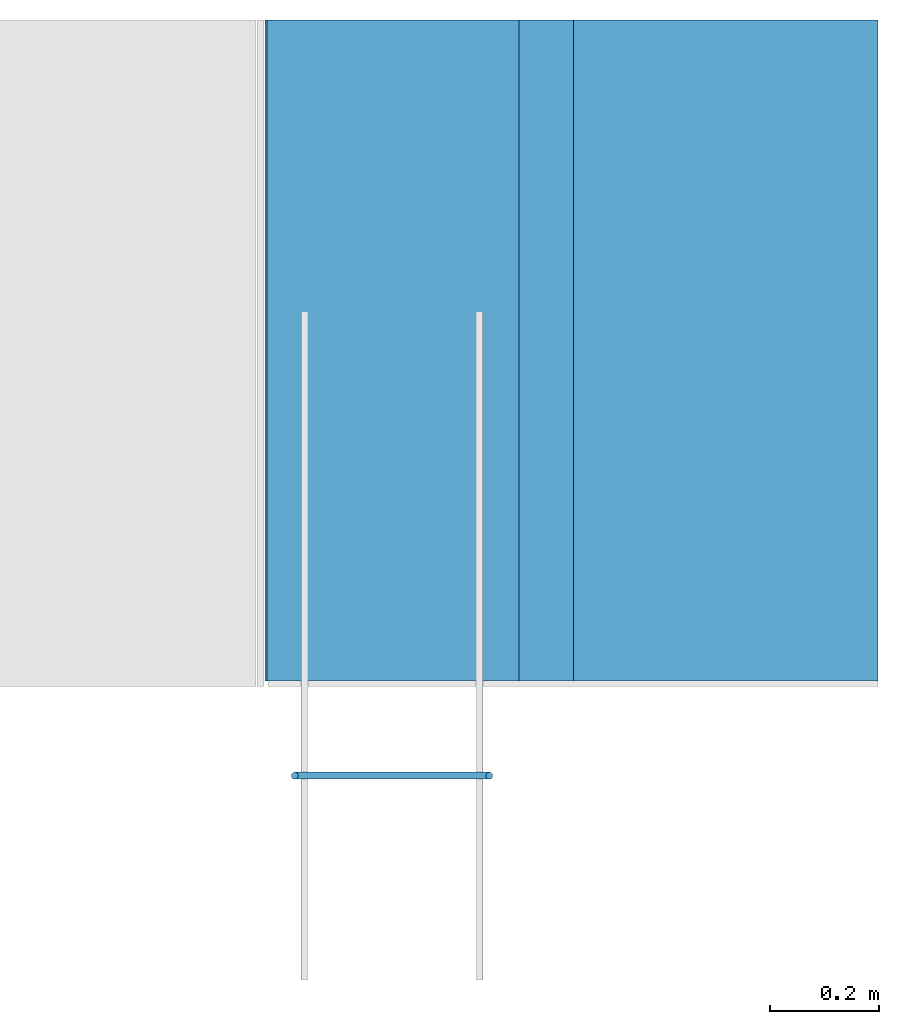
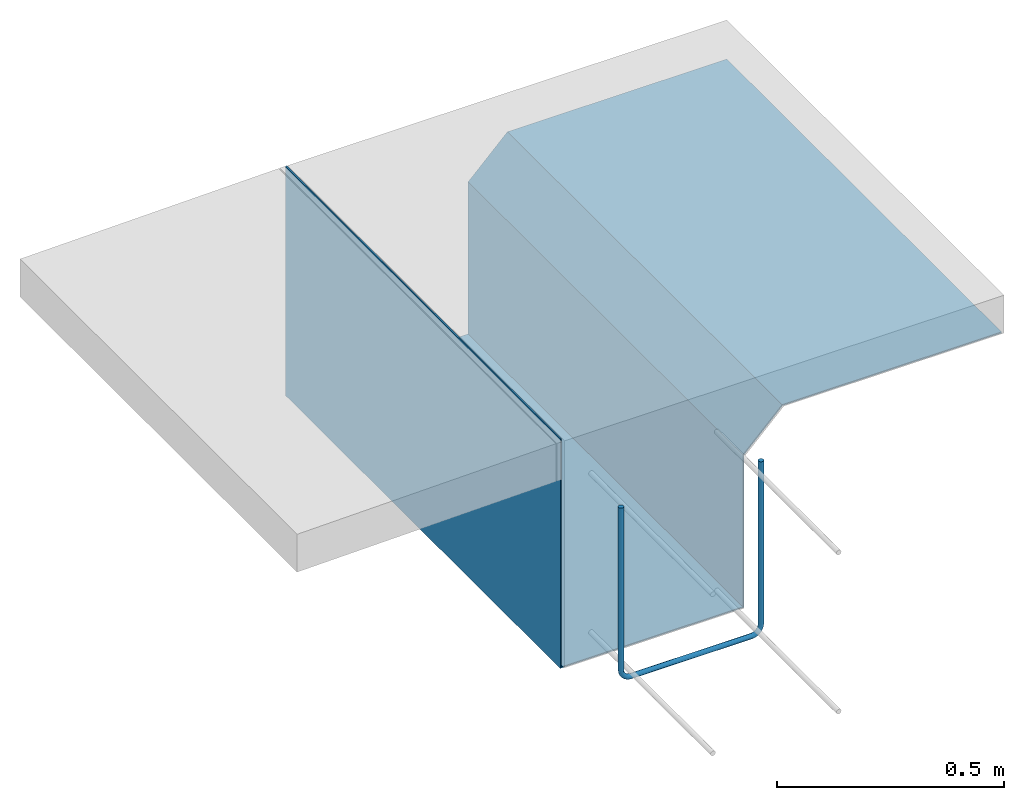
# One storey, part 2 of 2: 2 walls.
"""IFC4 building model written with IfcOpenShell, lengths in feet."""

from ifc_helpers import new_model, entity, si_unit, converted_unit, derived_unit, direction, frame, origin, place, context, subcontext, project, spatial, material, type_object, element, save


model = new_model("IFC4")

# Units and contexts
model_context = context("Model", 3, precision=0.0001, world=origin(), true_north=direction((6.12303176911189e-17, 1.0)))
body_context = subcontext(model_context, "Body", "Model", "MODEL_VIEW")
ifc_project = project(units=[converted_unit("LENGTHUNIT", "FOOT", entity("IfcRatioMeasure", 0.3048), si_unit("LENGTHUNIT", "METRE"), dimensions=[1, 0, 0, 0, 0, 0, 0]), converted_unit("AREAUNIT", "SQUARE FOOT", entity("IfcRatioMeasure", 0.09290304), si_unit("AREAUNIT", "SQUARE_METRE"), dimensions=[2, 0, 0, 0, 0, 0, 0]), converted_unit("VOLUMEUNIT", "CUBIC FOOT", entity("IfcRatioMeasure", 0.028316846592), si_unit("VOLUMEUNIT", "CUBIC_METRE"), dimensions=[3, 0, 0, 0, 0, 0, 0]), converted_unit("PLANEANGLEUNIT", "DEGREE", entity("IfcRatioMeasure", 0.0174532925199433), si_unit("PLANEANGLEUNIT", "RADIAN"), dimensions=[0, 0, 0, 0, 0, 0, 0]), si_unit("MASSUNIT", "GRAM", prefix="KILO"), derived_unit("MASSDENSITYUNIT", [(si_unit("MASSUNIT", "GRAM", prefix="KILO"), 1), (si_unit("LENGTHUNIT", "METRE"), -3)]), derived_unit("MOMENTOFINERTIAUNIT", [(si_unit("LENGTHUNIT", "METRE"), 4)]), si_unit("TIMEUNIT", "SECOND"), si_unit("FREQUENCYUNIT", "HERTZ"), si_unit("THERMODYNAMICTEMPERATUREUNIT", "DEGREE_CELSIUS"), derived_unit("THERMALTRANSMITTANCEUNIT", [(si_unit("MASSUNIT", "GRAM", prefix="KILO"), 1), (si_unit("THERMODYNAMICTEMPERATUREUNIT", "KELVIN"), -1), (si_unit("TIMEUNIT", "SECOND"), -3)]), derived_unit("VOLUMETRICFLOWRATEUNIT", [(si_unit("LENGTHUNIT", "METRE"), 3), (si_unit("TIMEUNIT", "SECOND"), -1)]), si_unit("ELECTRICCURRENTUNIT", "AMPERE"), si_unit("ELECTRICVOLTAGEUNIT", "VOLT"), si_unit("POWERUNIT", "WATT"), si_unit("FORCEUNIT", "NEWTON"), si_unit("ILLUMINANCEUNIT", "LUX"), si_unit("LUMINOUSFLUXUNIT", "LUMEN"), si_unit("LUMINOUSINTENSITYUNIT", "CANDELA"), derived_unit("USERDEFINED", [(si_unit("MASSUNIT", "GRAM", prefix="KILO"), -1), (si_unit("LENGTHUNIT", "METRE"), -2), (si_unit("TIMEUNIT", "SECOND"), 3), (si_unit("LUMINOUSFLUXUNIT", "LUMEN"), 1)]), derived_unit("LINEARVELOCITYUNIT", [(si_unit("LENGTHUNIT", "METRE"), 1), (si_unit("TIMEUNIT", "SECOND"), -1)]), si_unit("PRESSUREUNIT", "PASCAL"), derived_unit("USERDEFINED", [(si_unit("LENGTHUNIT", "METRE"), -2), (si_unit("MASSUNIT", "GRAM", prefix="KILO"), 1), (si_unit("TIMEUNIT", "SECOND"), -2)]), derived_unit("LINEARFORCEUNIT", [(si_unit("MASSUNIT", "GRAM", prefix="KILO"), 1), (si_unit("LENGTHUNIT", "METRE"), 1), (si_unit("TIMEUNIT", "SECOND"), -2), (si_unit("LENGTHUNIT", "METRE"), -1)]), derived_unit("PLANARFORCEUNIT", [(si_unit("MASSUNIT", "GRAM", prefix="KILO"), 1), (si_unit("LENGTHUNIT", "METRE"), 1), (si_unit("TIMEUNIT", "SECOND"), -2), (si_unit("LENGTHUNIT", "METRE"), -2)])], contexts=[model_context])

# Site, building, storey
site_placement = place(None, origin())
site = spatial("IfcSite", under=ifc_project, at=site_placement, CompositionType="ELEMENT")
building_placement = place(site_placement, origin())
building = spatial("IfcBuilding", under=site, at=building_placement, CompositionType="ELEMENT")
storey_placement = place(building_placement, frame((0.0, 0.0, -8.0)))
storey = spatial("IfcBuildingStorey", under=building, at=storey_placement, CompositionType="ELEMENT", Elevation=-8.0)

# Walls
ifc_material_1 = material(Category="Materials")
wall_type_1 = type_object("IfcWallType", Name="Dowel2:Dowel", PredefinedType="NOTDEFINED", material=ifc_material_1)
wall_1_placement = place(storey_placement, frame((1459.41212853002, 1.44531249999566, 6.14583333332428)))
cartesian_point_1 = entity("IfcCartesianPoint", [0.0, 0.020833333333343, 1.54252768189775])
vertex_point_1 = entity("IfcVertexPoint", cartesian_point_1)
cartesian_point_2 = entity("IfcCartesianPoint", [0.0416666666665151, 0.0208333333333424, 1.54252768189775])
vertex_point_2 = entity("IfcVertexPoint", cartesian_point_2)
cartesian_point_3 = entity("IfcCartesianPoint", [0.0208333333332575, 0.0208333333333428, 1.54252768189775])
ifc_direction_1 = entity("IfcDirection", [0.0, 0.0, 1.0])
ifc_direction_2 = entity("IfcDirection", [1.0, 0.0, 0.0])
edge_curve_1 = entity("IfcEdgeCurve", vertex_point_1, vertex_point_2, entity("IfcTrimmedCurve", entity("IfcCircle", entity("IfcAxis2Placement3D", cartesian_point_3, ifc_direction_1, ifc_direction_2), 0.0208333333333333), [cartesian_point_1], [cartesian_point_2], True, "CARTESIAN"), True)
edge_curve_2 = entity("IfcEdgeCurve", vertex_point_2, vertex_point_1, entity("IfcTrimmedCurve", entity("IfcCircle", entity("IfcAxis2Placement3D", cartesian_point_3, ifc_direction_1, ifc_direction_2), 0.0208333333333333), [cartesian_point_2], [cartesian_point_1], True, "CARTESIAN"), True)
ifc_direction_3 = entity("IfcDirection", [0.0, -1.0, 0.0])
cartesian_point_4 = entity("IfcCartesianPoint", [0.0, 0.0208333333333384, 0.104166666666667])
vertex_point_3 = entity("IfcVertexPoint", cartesian_point_4)
ifc_direction_4 = entity("IfcDirection", [0.0, 0.0, -1.0])
edge_curve_3 = entity("IfcEdgeCurve", vertex_point_1, vertex_point_3, entity("IfcTrimmedCurve", entity("IfcLine", cartesian_point_1, entity("IfcVector", ifc_direction_4, 1.0)), [cartesian_point_1], [cartesian_point_4], True, "CARTESIAN"), True)
cartesian_point_5 = entity("IfcCartesianPoint", [0.0416666666665151, 0.020833333333337, 0.104166666666667])
vertex_point_4 = entity("IfcVertexPoint", cartesian_point_5)
cartesian_point_6 = entity("IfcCartesianPoint", [0.0208333333332575, 0.0208333333333381, 0.104166666666667])
edge_curve_4 = entity("IfcEdgeCurve", vertex_point_3, vertex_point_4, entity("IfcTrimmedCurve", entity("IfcCircle", entity("IfcAxis2Placement3D", cartesian_point_6, ifc_direction_1, ifc_direction_2), 0.0208333333333333), [cartesian_point_4], [cartesian_point_5], True, "CARTESIAN"), True)
edge_curve_5 = entity("IfcEdgeCurve", vertex_point_4, vertex_point_2, entity("IfcTrimmedCurve", entity("IfcLine", cartesian_point_2, entity("IfcVector", ifc_direction_1, 1.0)), [cartesian_point_5], [cartesian_point_2], True, "CARTESIAN"), True)
edge_curve_6 = entity("IfcEdgeCurve", vertex_point_4, vertex_point_3, entity("IfcTrimmedCurve", entity("IfcCircle", entity("IfcAxis2Placement3D", cartesian_point_6, ifc_direction_1, ifc_direction_2), 0.0208333333333333), [cartesian_point_5], [cartesian_point_4], True, "CARTESIAN"), True)
cartesian_point_7 = entity("IfcCartesianPoint", [0.104166666666515, 0.0208333333333366, 0.041666666666738])
vertex_point_5 = entity("IfcVertexPoint", cartesian_point_7)
cartesian_point_8 = entity("IfcCartesianPoint", [0.104166666666515, 0.0208333333333373, 0.104166666666667])
ifc_direction_5 = entity("IfcDirection", [0.0, 1.0, 0.0])
ifc_direction_6 = entity("IfcDirection", [-1.0, 0.0, 0.0])
edge_curve_7 = entity("IfcEdgeCurve", vertex_point_5, vertex_point_4, entity("IfcTrimmedCurve", entity("IfcCircle", entity("IfcAxis2Placement3D", cartesian_point_8, ifc_direction_5, ifc_direction_6), 0.0625), [cartesian_point_7], [cartesian_point_5], True, "CARTESIAN"), True)
cartesian_point_9 = entity("IfcCartesianPoint", [0.104166666666515, 0.020833333333337, 0.0])
vertex_point_6 = entity("IfcVertexPoint", cartesian_point_9)
edge_curve_8 = entity("IfcEdgeCurve", vertex_point_3, vertex_point_6, entity("IfcTrimmedCurve", entity("IfcCircle", entity("IfcAxis2Placement3D", cartesian_point_8, ifc_direction_3, ifc_direction_6), 0.104166666666515), [cartesian_point_4], [cartesian_point_9], True, "CARTESIAN"), True)
cartesian_point_10 = entity("IfcCartesianPoint", [0.104166666666515, 0.0208333333333368, 0.0208333333332784])
edge_curve_9 = entity("IfcEdgeCurve", vertex_point_6, vertex_point_5, entity("IfcTrimmedCurve", entity("IfcCircle", entity("IfcAxis2Placement3D", cartesian_point_10, ifc_direction_6, ifc_direction_1), 0.0208333333333333), [cartesian_point_9], [cartesian_point_7], True, "CARTESIAN"), True)
edge_curve_10 = entity("IfcEdgeCurve", vertex_point_5, vertex_point_6, entity("IfcTrimmedCurve", entity("IfcCircle", entity("IfcAxis2Placement3D", cartesian_point_10, ifc_direction_6, ifc_direction_1), 0.0208333333333333), [cartesian_point_7], [cartesian_point_9], True, "CARTESIAN"), True)
cartesian_point_11 = entity("IfcCartesianPoint", [1.20833333333303, 0.0208333333333448, 1.54252768189761])
vertex_point_7 = entity("IfcVertexPoint", cartesian_point_11)
cartesian_point_12 = entity("IfcCartesianPoint", [1.16666666666652, 0.0208333333333446, 1.54252768189761])
vertex_point_8 = entity("IfcVertexPoint", cartesian_point_12)
cartesian_point_13 = entity("IfcCartesianPoint", [1.18749999999977, 0.0208333333333446, 1.54252768189775])
edge_curve_11 = entity("IfcEdgeCurve", vertex_point_7, vertex_point_8, entity("IfcTrimmedCurve", entity("IfcCircle", entity("IfcAxis2Placement3D", cartesian_point_13, ifc_direction_1, ifc_direction_6), 0.0208333333333333), [cartesian_point_11], [cartesian_point_12], True, "CARTESIAN"), True)
edge_curve_12 = entity("IfcEdgeCurve", vertex_point_8, vertex_point_7, entity("IfcTrimmedCurve", entity("IfcCircle", entity("IfcAxis2Placement3D", cartesian_point_13, ifc_direction_1, ifc_direction_6), 0.0208333333333333), [cartesian_point_12], [cartesian_point_11], True, "CARTESIAN"), True)
cartesian_point_14 = entity("IfcCartesianPoint", [1.10416666666629, 0.0208333333333337, 0.0])
vertex_point_9 = entity("IfcVertexPoint", cartesian_point_14)
edge_curve_13 = entity("IfcEdgeCurve", vertex_point_6, vertex_point_9, entity("IfcTrimmedCurve", entity("IfcLine", cartesian_point_9, entity("IfcVector", ifc_direction_2, 1.0)), [cartesian_point_9], [cartesian_point_14], True, "CARTESIAN"), True)
cartesian_point_15 = entity("IfcCartesianPoint", [1.10416666666629, 0.0208333333333373, 0.0416666666666665])
vertex_point_10 = entity("IfcVertexPoint", cartesian_point_15)
cartesian_point_16 = entity("IfcCartesianPoint", [1.10416666666629, 0.0208333333333337, 0.020833333333333])
edge_curve_14 = entity("IfcEdgeCurve", vertex_point_9, vertex_point_10, entity("IfcTrimmedCurve", entity("IfcCircle", entity("IfcAxis2Placement3D", cartesian_point_16, ifc_direction_6, ifc_direction_1), 0.0208333333333333), [cartesian_point_14], [cartesian_point_15], True, "CARTESIAN"), True)
edge_curve_15 = entity("IfcEdgeCurve", vertex_point_10, vertex_point_5, entity("IfcTrimmedCurve", entity("IfcLine", cartesian_point_7, entity("IfcVector", ifc_direction_6, 1.0)), [cartesian_point_15], [cartesian_point_7], True, "CARTESIAN"), True)
edge_curve_16 = entity("IfcEdgeCurve", vertex_point_10, vertex_point_9, entity("IfcTrimmedCurve", entity("IfcCircle", entity("IfcAxis2Placement3D", cartesian_point_16, ifc_direction_6, ifc_direction_1), 0.0208333333333333), [cartesian_point_15], [cartesian_point_14], True, "CARTESIAN"), True)
cartesian_point_17 = entity("IfcCartesianPoint", [1.16666666666652, 0.0208333333333399, 0.104166666666667])
vertex_point_11 = entity("IfcVertexPoint", cartesian_point_17)
cartesian_point_18 = entity("IfcCartesianPoint", [1.20833333333303, 0.0208333333333401, 0.104166666666667])
vertex_point_12 = entity("IfcVertexPoint", cartesian_point_18)
cartesian_point_19 = entity("IfcCartesianPoint", [1.18749999999955, 0.0208333333333377, 0.104166666666624])
edge_curve_17 = entity("IfcEdgeCurve", vertex_point_11, vertex_point_12, entity("IfcTrimmedCurve", entity("IfcCircle", entity("IfcAxis2Placement3D", cartesian_point_19, ifc_direction_1, ifc_direction_6), 0.0208333333333333), [cartesian_point_17], [cartesian_point_18], True, "CARTESIAN"), True)
edge_curve_18 = entity("IfcEdgeCurve", vertex_point_12, vertex_point_7, entity("IfcTrimmedCurve", entity("IfcLine", cartesian_point_18, entity("IfcVector", ifc_direction_1, 1.0)), [cartesian_point_18], [cartesian_point_11], True, "CARTESIAN"), True)
edge_curve_19 = entity("IfcEdgeCurve", vertex_point_8, vertex_point_11, entity("IfcTrimmedCurve", entity("IfcLine", cartesian_point_17, entity("IfcVector", ifc_direction_4, 1.0)), [cartesian_point_12], [cartesian_point_17], True, "CARTESIAN"), True)
edge_curve_20 = entity("IfcEdgeCurve", vertex_point_12, vertex_point_11, entity("IfcTrimmedCurve", entity("IfcCircle", entity("IfcAxis2Placement3D", cartesian_point_19, ifc_direction_1, ifc_direction_6), 0.0208333333333333), [cartesian_point_18], [cartesian_point_17], True, "CARTESIAN"), True)
cartesian_point_20 = entity("IfcCartesianPoint", [1.10416666666629, 0.0208333333333377, 0.104166666666667])
edge_curve_21 = entity("IfcEdgeCurve", vertex_point_11, vertex_point_10, entity("IfcTrimmedCurve", entity("IfcCircle", entity("IfcAxis2Placement3D", cartesian_point_20, ifc_direction_5, ifc_direction_4), 0.0624999999999913), [cartesian_point_17], [cartesian_point_15], True, "CARTESIAN"), True)
edge_curve_22 = entity("IfcEdgeCurve", vertex_point_9, vertex_point_12, entity("IfcTrimmedCurve", entity("IfcCircle", entity("IfcAxis2Placement3D", cartesian_point_20, ifc_direction_3, ifc_direction_4), 0.104166666666658), [cartesian_point_14], [cartesian_point_18], True, "CARTESIAN"), True)
element("IfcWall", 1, at=wall_1_placement, inside=storey, type_object=wall_type_1, material=ifc_material_1, Name="Dowel2:Dowel", ObjectType="Dowel2:Dowel", PredefinedType="NOTDEFINED", context=body_context, shape_type="AdvancedBrep", body=[
    entity("IfcAdvancedBrep", entity("IfcClosedShell", [entity("IfcAdvancedFace", [entity("IfcFaceOuterBound", entity("IfcEdgeLoop", [entity("IfcOrientedEdge", None, None, edge_curve_1, True), entity("IfcOrientedEdge", None, None, edge_curve_2, True)]), True)], entity("IfcPlane", entity("IfcAxis2Placement3D", cartesian_point_3, ifc_direction_1, ifc_direction_3)), True), entity("IfcAdvancedFace", [entity("IfcFaceOuterBound", entity("IfcEdgeLoop", [entity("IfcOrientedEdge", None, None, edge_curve_1, False), entity("IfcOrientedEdge", None, None, edge_curve_3, True), entity("IfcOrientedEdge", None, None, edge_curve_4, True), entity("IfcOrientedEdge", None, None, edge_curve_5, True)]), True)], entity("IfcCylindricalSurface", entity("IfcAxis2Placement3D", cartesian_point_3, ifc_direction_1, ifc_direction_2), 0.0208333333333333), True), entity("IfcAdvancedFace", [entity("IfcFaceOuterBound", entity("IfcEdgeLoop", [entity("IfcOrientedEdge", None, None, edge_curve_2, False), entity("IfcOrientedEdge", None, None, edge_curve_5, False), entity("IfcOrientedEdge", None, None, edge_curve_6, True), entity("IfcOrientedEdge", None, None, edge_curve_3, False)]), True)], entity("IfcCylindricalSurface", entity("IfcAxis2Placement3D", cartesian_point_3, ifc_direction_1, ifc_direction_2), 0.0208333333333333), True), entity("IfcAdvancedFace", [entity("IfcFaceOuterBound", entity("IfcEdgeLoop", [entity("IfcOrientedEdge", None, None, edge_curve_7, True), entity("IfcOrientedEdge", None, None, edge_curve_4, False), entity("IfcOrientedEdge", None, None, edge_curve_8, True), entity("IfcOrientedEdge", None, None, edge_curve_9, True)]), True)], entity("IfcSurfaceOfRevolution", entity("IfcArbitraryOpenProfileDef", "CURVE", None, entity("IfcTrimmedCurve", entity("IfcCircle", entity("IfcAxis2Placement3D", cartesian_point_10, ifc_direction_6, ifc_direction_1), 0.0208333333333333), [cartesian_point_9], [cartesian_point_7], True, "CARTESIAN")), None, entity("IfcAxis1Placement", cartesian_point_8, ifc_direction_3)), True), entity("IfcAdvancedFace", [entity("IfcFaceOuterBound", entity("IfcEdgeLoop", [entity("IfcOrientedEdge", None, None, edge_curve_8, False), entity("IfcOrientedEdge", None, None, edge_curve_6, False), entity("IfcOrientedEdge", None, None, edge_curve_7, False), entity("IfcOrientedEdge", None, None, edge_curve_10, True)]), True)], entity("IfcSurfaceOfRevolution", entity("IfcArbitraryOpenProfileDef", "CURVE", None, entity("IfcTrimmedCurve", entity("IfcCircle", entity("IfcAxis2Placement3D", cartesian_point_10, ifc_direction_6, ifc_direction_1), 0.0208333333333333), [cartesian_point_7], [cartesian_point_9], True, "CARTESIAN")), None, entity("IfcAxis1Placement", cartesian_point_8, ifc_direction_3)), True), entity("IfcAdvancedFace", [entity("IfcFaceOuterBound", entity("IfcEdgeLoop", [entity("IfcOrientedEdge", None, None, edge_curve_11, True), entity("IfcOrientedEdge", None, None, edge_curve_12, True)]), True)], entity("IfcPlane", entity("IfcAxis2Placement3D", cartesian_point_13, ifc_direction_1, ifc_direction_3)), True), entity("IfcAdvancedFace", [entity("IfcFaceOuterBound", entity("IfcEdgeLoop", [entity("IfcOrientedEdge", None, None, edge_curve_9, False), entity("IfcOrientedEdge", None, None, edge_curve_13, True), entity("IfcOrientedEdge", None, None, edge_curve_14, True), entity("IfcOrientedEdge", None, None, edge_curve_15, True)]), True)], entity("IfcCylindricalSurface", entity("IfcAxis2Placement3D", cartesian_point_10, ifc_direction_6, ifc_direction_1), 0.0208333333333333), True), entity("IfcAdvancedFace", [entity("IfcFaceOuterBound", entity("IfcEdgeLoop", [entity("IfcOrientedEdge", None, None, edge_curve_10, False), entity("IfcOrientedEdge", None, None, edge_curve_15, False), entity("IfcOrientedEdge", None, None, edge_curve_16, True), entity("IfcOrientedEdge", None, None, edge_curve_13, False)]), True)], entity("IfcCylindricalSurface", entity("IfcAxis2Placement3D", cartesian_point_10, ifc_direction_6, ifc_direction_1), 0.0208333333333333), True), entity("IfcAdvancedFace", [entity("IfcFaceOuterBound", entity("IfcEdgeLoop", [entity("IfcOrientedEdge", None, None, edge_curve_17, True), entity("IfcOrientedEdge", None, None, edge_curve_18, True), entity("IfcOrientedEdge", None, None, edge_curve_12, False), entity("IfcOrientedEdge", None, None, edge_curve_19, True)]), True)], entity("IfcCylindricalSurface", entity("IfcAxis2Placement3D", cartesian_point_19, ifc_direction_4, ifc_direction_6), 0.0208333333333333), True), entity("IfcAdvancedFace", [entity("IfcFaceOuterBound", entity("IfcEdgeLoop", [entity("IfcOrientedEdge", None, None, edge_curve_20, True), entity("IfcOrientedEdge", None, None, edge_curve_19, False), entity("IfcOrientedEdge", None, None, edge_curve_11, False), entity("IfcOrientedEdge", None, None, edge_curve_18, False)]), True)], entity("IfcCylindricalSurface", entity("IfcAxis2Placement3D", cartesian_point_19, ifc_direction_4, ifc_direction_6), 0.0208333333333333), True), entity("IfcAdvancedFace", [entity("IfcFaceOuterBound", entity("IfcEdgeLoop", [entity("IfcOrientedEdge", None, None, edge_curve_21, True), entity("IfcOrientedEdge", None, None, edge_curve_14, False), entity("IfcOrientedEdge", None, None, edge_curve_22, True), entity("IfcOrientedEdge", None, None, edge_curve_17, False)]), True)], entity("IfcSurfaceOfRevolution", entity("IfcArbitraryOpenProfileDef", "CURVE", None, entity("IfcTrimmedCurve", entity("IfcCircle", entity("IfcAxis2Placement3D", cartesian_point_16, ifc_direction_6, ifc_direction_1), 0.0208333333333333), [cartesian_point_14], [cartesian_point_15], True, "CARTESIAN")), None, entity("IfcAxis1Placement", cartesian_point_20, ifc_direction_3)), True), entity("IfcAdvancedFace", [entity("IfcFaceOuterBound", entity("IfcEdgeLoop", [entity("IfcOrientedEdge", None, None, edge_curve_22, False), entity("IfcOrientedEdge", None, None, edge_curve_16, False), entity("IfcOrientedEdge", None, None, edge_curve_21, False), entity("IfcOrientedEdge", None, None, edge_curve_20, False)]), True)], entity("IfcSurfaceOfRevolution", entity("IfcArbitraryOpenProfileDef", "CURVE", None, entity("IfcTrimmedCurve", entity("IfcCircle", entity("IfcAxis2Placement3D", cartesian_point_16, ifc_direction_6, ifc_direction_1), 0.0208333333333333), [cartesian_point_15], [cartesian_point_14], True, "CARTESIAN")), None, entity("IfcAxis1Placement", cartesian_point_20, ifc_direction_3)), True)])),
])
ifc_material_2 = material(Name="6 MIL VAPOR BARRIER", Category="Materials")
wall_type_2 = type_object("IfcWallType", Name="Walls 16:Walls 16", PredefinedType="NOTDEFINED", material=ifc_material_2)
wall_2_placement = place(storey_placement, frame((1459.25523801479, 2.03457850478325, 5.9791666666576), z_axis=(0.0, 0.0, 1.0), x_axis=(0.0, 1.0, 0.0)))
cartesian_point_21 = entity("IfcCartesianPoint", [0.0, -1.85301996444127, 1.66666666666661])
vertex_point_13 = entity("IfcVertexPoint", cartesian_point_21)
cartesian_point_22 = entity("IfcCartesianPoint", [0.0, -3.67772384855857, 1.66666666666667])
vertex_point_14 = entity("IfcVertexPoint", cartesian_point_22)
ifc_direction_7 = entity("IfcDirection", [0.0, -1.0, 0.0])
edge_curve_23 = entity("IfcEdgeCurve", vertex_point_13, vertex_point_14, entity("IfcTrimmedCurve", entity("IfcLine", cartesian_point_21, entity("IfcVector", ifc_direction_7, 1.0)), [cartesian_point_21], [cartesian_point_22], True, "CARTESIAN"), True)
cartesian_point_23 = entity("IfcCartesianPoint", [0.0, -3.67772384855857, 1.67708333333334])
vertex_point_15 = entity("IfcVertexPoint", cartesian_point_23)
ifc_direction_8 = entity("IfcDirection", [0.0, 0.0, 1.0])
edge_curve_24 = entity("IfcEdgeCurve", vertex_point_14, vertex_point_15, entity("IfcTrimmedCurve", entity("IfcLine", cartesian_point_22, entity("IfcVector", ifc_direction_8, 1.0)), [cartesian_point_22], [cartesian_point_23], True, "CARTESIAN"), True)
cartesian_point_24 = entity("IfcCartesianPoint", [0.0, -1.84870523983318, 1.67708333333332])
vertex_point_16 = entity("IfcVertexPoint", cartesian_point_24)
ifc_direction_9 = entity("IfcDirection", [0.0, 1.0, 0.0])
edge_curve_25 = entity("IfcEdgeCurve", vertex_point_15, vertex_point_16, entity("IfcTrimmedCurve", entity("IfcLine", cartesian_point_23, entity("IfcVector", ifc_direction_9, 1.0)), [cartesian_point_23], [cartesian_point_24], True, "CARTESIAN"), True)
cartesian_point_25 = entity("IfcCartesianPoint", [0.0, -1.52147384855834, 1.34985194205855])
vertex_point_17 = entity("IfcVertexPoint", cartesian_point_25)
edge_curve_26 = entity("IfcEdgeCurve", vertex_point_16, vertex_point_17, entity("IfcTrimmedCurve", entity("IfcLine", cartesian_point_24, entity("IfcVector", entity("IfcDirection", [0.0, 0.707106781186616, -0.707106781186479]), 1.0)), [cartesian_point_24], [cartesian_point_25], True, "CARTESIAN"), True)
cartesian_point_26 = entity("IfcCartesianPoint", [0.0, -1.52147384855834, 0.0104166666666736])
vertex_point_18 = entity("IfcVertexPoint", cartesian_point_26)
ifc_direction_10 = entity("IfcDirection", [0.0, 0.0, -1.0])
edge_curve_27 = entity("IfcEdgeCurve", vertex_point_17, vertex_point_18, entity("IfcTrimmedCurve", entity("IfcLine", cartesian_point_25, entity("IfcVector", ifc_direction_10, 1.0)), [cartesian_point_25], [cartesian_point_26], True, "CARTESIAN"), True)
cartesian_point_27 = entity("IfcCartesianPoint", [0.0, -0.0104166666667425, 0.0104166666666736])
vertex_point_19 = entity("IfcVertexPoint", cartesian_point_27)
edge_curve_28 = entity("IfcEdgeCurve", vertex_point_18, vertex_point_19, entity("IfcTrimmedCurve", entity("IfcLine", cartesian_point_26, entity("IfcVector", ifc_direction_9, 1.0)), [cartesian_point_26], [cartesian_point_27], True, "CARTESIAN"), True)
cartesian_point_28 = entity("IfcCartesianPoint", [0.0, -0.0104166666667425, 2.02083333333312])
vertex_point_20 = entity("IfcVertexPoint", cartesian_point_28)
edge_curve_29 = entity("IfcEdgeCurve", vertex_point_19, vertex_point_20, entity("IfcTrimmedCurve", entity("IfcLine", cartesian_point_27, entity("IfcVector", ifc_direction_8, 1.0)), [cartesian_point_27], [cartesian_point_28], True, "CARTESIAN"), True)
cartesian_point_29 = entity("IfcCartesianPoint", [0.0, 0.0, 2.02083333333312])
vertex_point_21 = entity("IfcVertexPoint", cartesian_point_29)
edge_curve_30 = entity("IfcEdgeCurve", vertex_point_20, vertex_point_21, entity("IfcTrimmedCurve", entity("IfcLine", cartesian_point_28, entity("IfcVector", ifc_direction_9, 1.0)), [cartesian_point_28], [cartesian_point_29], True, "CARTESIAN"), True)
cartesian_point_30 = entity("IfcCartesianPoint", [0.0, 0.0, 0.0])
vertex_point_22 = entity("IfcVertexPoint", cartesian_point_30)
edge_curve_31 = entity("IfcEdgeCurve", vertex_point_21, vertex_point_22, entity("IfcTrimmedCurve", entity("IfcLine", cartesian_point_29, entity("IfcVector", ifc_direction_10, 1.0)), [cartesian_point_29], [cartesian_point_30], True, "CARTESIAN"), True)
cartesian_point_31 = entity("IfcCartesianPoint", [0.0, -1.53189051522509, 0.0])
vertex_point_23 = entity("IfcVertexPoint", cartesian_point_31)
edge_curve_32 = entity("IfcEdgeCurve", vertex_point_22, vertex_point_23, entity("IfcTrimmedCurve", entity("IfcLine", cartesian_point_30, entity("IfcVector", ifc_direction_7, 1.0)), [cartesian_point_30], [cartesian_point_31], True, "CARTESIAN"), True)
cartesian_point_32 = entity("IfcCartesianPoint", [0.0, -1.53189051522509, 1.34553721745048])
vertex_point_24 = entity("IfcVertexPoint", cartesian_point_32)
edge_curve_33 = entity("IfcEdgeCurve", vertex_point_23, vertex_point_24, entity("IfcTrimmedCurve", entity("IfcLine", cartesian_point_31, entity("IfcVector", ifc_direction_8, 1.0)), [cartesian_point_31], [cartesian_point_32], True, "CARTESIAN"), True)
edge_curve_34 = entity("IfcEdgeCurve", vertex_point_24, vertex_point_13, entity("IfcTrimmedCurve", entity("IfcLine", cartesian_point_32, entity("IfcVector", entity("IfcDirection", [0.0, -0.707106781186601, 0.707106781186494]), 1.0)), [cartesian_point_32], [cartesian_point_21], True, "CARTESIAN"), True)
ifc_direction_11 = entity("IfcDirection", [-1.0, 0.0, 0.0])
cartesian_point_33 = entity("IfcCartesianPoint", [3.96542149521276, -1.85301996444127, 1.6666666666666])
vertex_point_25 = entity("IfcVertexPoint", cartesian_point_33)
cartesian_point_34 = entity("IfcCartesianPoint", [3.96542149521276, -1.53189051522509, 1.34553721745046])
vertex_point_26 = entity("IfcVertexPoint", cartesian_point_34)
edge_curve_35 = entity("IfcEdgeCurve", vertex_point_25, vertex_point_26, entity("IfcTrimmedCurve", entity("IfcLine", cartesian_point_33, entity("IfcVector", entity("IfcDirection", [0.0, 0.707106781186601, -0.707106781186494]), 1.0)), [cartesian_point_33], [cartesian_point_34], True, "CARTESIAN"), True)
cartesian_point_35 = entity("IfcCartesianPoint", [3.96542149521276, -1.53189051522509, 0.0])
vertex_point_27 = entity("IfcVertexPoint", cartesian_point_35)
edge_curve_36 = entity("IfcEdgeCurve", vertex_point_26, vertex_point_27, entity("IfcTrimmedCurve", entity("IfcLine", cartesian_point_34, entity("IfcVector", ifc_direction_10, 1.0)), [cartesian_point_34], [cartesian_point_35], True, "CARTESIAN"), True)
cartesian_point_36 = entity("IfcCartesianPoint", [3.96542149521275, 0.0, 0.0])
vertex_point_28 = entity("IfcVertexPoint", cartesian_point_36)
edge_curve_37 = entity("IfcEdgeCurve", vertex_point_27, vertex_point_28, entity("IfcTrimmedCurve", entity("IfcLine", cartesian_point_35, entity("IfcVector", ifc_direction_9, 1.0)), [cartesian_point_35], [cartesian_point_36], True, "CARTESIAN"), True)
cartesian_point_37 = entity("IfcCartesianPoint", [3.96542149521275, 0.0, 2.02083333333312])
vertex_point_29 = entity("IfcVertexPoint", cartesian_point_37)
edge_curve_38 = entity("IfcEdgeCurve", vertex_point_28, vertex_point_29, entity("IfcTrimmedCurve", entity("IfcLine", cartesian_point_36, entity("IfcVector", ifc_direction_8, 1.0)), [cartesian_point_36], [cartesian_point_37], True, "CARTESIAN"), True)
cartesian_point_38 = entity("IfcCartesianPoint", [3.96542149521275, -0.0104166666667425, 2.02083333333312])
vertex_point_30 = entity("IfcVertexPoint", cartesian_point_38)
edge_curve_39 = entity("IfcEdgeCurve", vertex_point_29, vertex_point_30, entity("IfcTrimmedCurve", entity("IfcLine", cartesian_point_37, entity("IfcVector", ifc_direction_7, 1.0)), [cartesian_point_37], [cartesian_point_38], True, "CARTESIAN"), True)
cartesian_point_39 = entity("IfcCartesianPoint", [3.96542149521275, -0.0104166666667425, 0.0104166666666665])
vertex_point_31 = entity("IfcVertexPoint", cartesian_point_39)
edge_curve_40 = entity("IfcEdgeCurve", vertex_point_30, vertex_point_31, entity("IfcTrimmedCurve", entity("IfcLine", cartesian_point_38, entity("IfcVector", ifc_direction_10, 1.0)), [cartesian_point_38], [cartesian_point_39], True, "CARTESIAN"), True)
cartesian_point_40 = entity("IfcCartesianPoint", [3.96542149521276, -1.52147384855834, 0.0104166666666665])
vertex_point_32 = entity("IfcVertexPoint", cartesian_point_40)
edge_curve_41 = entity("IfcEdgeCurve", vertex_point_31, vertex_point_32, entity("IfcTrimmedCurve", entity("IfcLine", cartesian_point_39, entity("IfcVector", ifc_direction_7, 1.0)), [cartesian_point_39], [cartesian_point_40], True, "CARTESIAN"), True)
cartesian_point_41 = entity("IfcCartesianPoint", [3.96542149521276, -1.52147384855834, 1.34985194205854])
vertex_point_33 = entity("IfcVertexPoint", cartesian_point_41)
edge_curve_42 = entity("IfcEdgeCurve", vertex_point_32, vertex_point_33, entity("IfcTrimmedCurve", entity("IfcLine", cartesian_point_40, entity("IfcVector", ifc_direction_8, 1.0)), [cartesian_point_40], [cartesian_point_41], True, "CARTESIAN"), True)
cartesian_point_42 = entity("IfcCartesianPoint", [3.96542149521276, -1.84870523983318, 1.67708333333331])
vertex_point_34 = entity("IfcVertexPoint", cartesian_point_42)
edge_curve_43 = entity("IfcEdgeCurve", vertex_point_33, vertex_point_34, entity("IfcTrimmedCurve", entity("IfcLine", cartesian_point_41, entity("IfcVector", entity("IfcDirection", [0.0, -0.707106781186616, 0.707106781186479]), 1.0)), [cartesian_point_41], [cartesian_point_42], True, "CARTESIAN"), True)
cartesian_point_43 = entity("IfcCartesianPoint", [3.96542149521277, -3.67772384855857, 1.67708333333333])
vertex_point_35 = entity("IfcVertexPoint", cartesian_point_43)
edge_curve_44 = entity("IfcEdgeCurve", vertex_point_34, vertex_point_35, entity("IfcTrimmedCurve", entity("IfcLine", cartesian_point_42, entity("IfcVector", ifc_direction_7, 1.0)), [cartesian_point_42], [cartesian_point_43], True, "CARTESIAN"), True)
cartesian_point_44 = entity("IfcCartesianPoint", [3.96542149521277, -3.67772384855857, 1.66666666666667])
vertex_point_36 = entity("IfcVertexPoint", cartesian_point_44)
edge_curve_45 = entity("IfcEdgeCurve", vertex_point_35, vertex_point_36, entity("IfcTrimmedCurve", entity("IfcLine", cartesian_point_43, entity("IfcVector", ifc_direction_10, 1.0)), [cartesian_point_43], [cartesian_point_44], True, "CARTESIAN"), True)
edge_curve_46 = entity("IfcEdgeCurve", vertex_point_36, vertex_point_25, entity("IfcTrimmedCurve", entity("IfcLine", cartesian_point_44, entity("IfcVector", ifc_direction_9, 1.0)), [cartesian_point_44], [cartesian_point_33], True, "CARTESIAN"), True)
ifc_direction_12 = entity("IfcDirection", [1.0, 0.0, 0.0])
edge_curve_47 = entity("IfcEdgeCurve", vertex_point_13, vertex_point_25, entity("IfcTrimmedCurve", entity("IfcLine", cartesian_point_21, entity("IfcVector", ifc_direction_12, 1.0)), [cartesian_point_21], [cartesian_point_33], True, "CARTESIAN"), True)
edge_curve_48 = entity("IfcEdgeCurve", vertex_point_36, vertex_point_14, entity("IfcTrimmedCurve", entity("IfcLine", cartesian_point_22, entity("IfcVector", ifc_direction_11, 1.0)), [cartesian_point_44], [cartesian_point_22], True, "CARTESIAN"), True)
edge_curve_49 = entity("IfcEdgeCurve", vertex_point_35, vertex_point_15, entity("IfcTrimmedCurve", entity("IfcLine", cartesian_point_23, entity("IfcVector", ifc_direction_11, 1.0)), [cartesian_point_43], [cartesian_point_23], True, "CARTESIAN"), True)
edge_curve_50 = entity("IfcEdgeCurve", vertex_point_34, vertex_point_16, entity("IfcTrimmedCurve", entity("IfcLine", cartesian_point_24, entity("IfcVector", ifc_direction_11, 1.0)), [cartesian_point_42], [cartesian_point_24], True, "CARTESIAN"), True)
edge_curve_51 = entity("IfcEdgeCurve", vertex_point_33, vertex_point_17, entity("IfcTrimmedCurve", entity("IfcLine", cartesian_point_25, entity("IfcVector", ifc_direction_11, 1.0)), [cartesian_point_41], [cartesian_point_25], True, "CARTESIAN"), True)
edge_curve_52 = entity("IfcEdgeCurve", vertex_point_32, vertex_point_18, entity("IfcTrimmedCurve", entity("IfcLine", cartesian_point_26, entity("IfcVector", ifc_direction_11, 1.0)), [cartesian_point_40], [cartesian_point_26], True, "CARTESIAN"), True)
edge_curve_53 = entity("IfcEdgeCurve", vertex_point_31, vertex_point_19, entity("IfcTrimmedCurve", entity("IfcLine", cartesian_point_27, entity("IfcVector", ifc_direction_11, 1.0)), [cartesian_point_39], [cartesian_point_27], True, "CARTESIAN"), True)
edge_curve_54 = entity("IfcEdgeCurve", vertex_point_30, vertex_point_20, entity("IfcTrimmedCurve", entity("IfcLine", cartesian_point_28, entity("IfcVector", ifc_direction_11, 1.0)), [cartesian_point_38], [cartesian_point_28], True, "CARTESIAN"), True)
edge_curve_55 = entity("IfcEdgeCurve", vertex_point_29, vertex_point_21, entity("IfcTrimmedCurve", entity("IfcLine", cartesian_point_29, entity("IfcVector", ifc_direction_11, 1.0)), [cartesian_point_37], [cartesian_point_29], True, "CARTESIAN"), True)
edge_curve_56 = entity("IfcEdgeCurve", vertex_point_28, vertex_point_22, entity("IfcTrimmedCurve", entity("IfcLine", cartesian_point_30, entity("IfcVector", ifc_direction_11, 1.0)), [cartesian_point_36], [cartesian_point_30], True, "CARTESIAN"), True)
edge_curve_57 = entity("IfcEdgeCurve", vertex_point_27, vertex_point_23, entity("IfcTrimmedCurve", entity("IfcLine", cartesian_point_31, entity("IfcVector", ifc_direction_11, 1.0)), [cartesian_point_35], [cartesian_point_31], True, "CARTESIAN"), True)
edge_curve_58 = entity("IfcEdgeCurve", vertex_point_26, vertex_point_24, entity("IfcTrimmedCurve", entity("IfcLine", cartesian_point_32, entity("IfcVector", ifc_direction_11, 1.0)), [cartesian_point_34], [cartesian_point_32], True, "CARTESIAN"), True)
element("IfcWall", 2, at=wall_2_placement, inside=storey, type_object=wall_type_2, material=ifc_material_2, Name="Walls 16:Walls 16", ObjectType="Walls 16:Walls 16", PredefinedType="NOTDEFINED", context=body_context, shape_type="AdvancedBrep", body=[
    entity("IfcAdvancedBrep", entity("IfcClosedShell", [entity("IfcAdvancedFace", [entity("IfcFaceOuterBound", entity("IfcEdgeLoop", [entity("IfcOrientedEdge", None, None, edge_curve_23, True), entity("IfcOrientedEdge", None, None, edge_curve_24, True), entity("IfcOrientedEdge", None, None, edge_curve_25, True), entity("IfcOrientedEdge", None, None, edge_curve_26, True), entity("IfcOrientedEdge", None, None, edge_curve_27, True), entity("IfcOrientedEdge", None, None, edge_curve_28, True), entity("IfcOrientedEdge", None, None, edge_curve_29, True), entity("IfcOrientedEdge", None, None, edge_curve_30, True), entity("IfcOrientedEdge", None, None, edge_curve_31, True), entity("IfcOrientedEdge", None, None, edge_curve_32, True), entity("IfcOrientedEdge", None, None, edge_curve_33, True), entity("IfcOrientedEdge", None, None, edge_curve_34, True)]), True)], entity("IfcPlane", entity("IfcAxis2Placement3D", entity("IfcCartesianPoint", [0.0, -1.84439051522531, 1.66666666666661]), ifc_direction_11, ifc_direction_7)), True), entity("IfcAdvancedFace", [entity("IfcFaceOuterBound", entity("IfcEdgeLoop", [entity("IfcOrientedEdge", None, None, edge_curve_35, True), entity("IfcOrientedEdge", None, None, edge_curve_36, True), entity("IfcOrientedEdge", None, None, edge_curve_37, True), entity("IfcOrientedEdge", None, None, edge_curve_38, True), entity("IfcOrientedEdge", None, None, edge_curve_39, True), entity("IfcOrientedEdge", None, None, edge_curve_40, True), entity("IfcOrientedEdge", None, None, edge_curve_41, True), entity("IfcOrientedEdge", None, None, edge_curve_42, True), entity("IfcOrientedEdge", None, None, edge_curve_43, True), entity("IfcOrientedEdge", None, None, edge_curve_44, True), entity("IfcOrientedEdge", None, None, edge_curve_45, True), entity("IfcOrientedEdge", None, None, edge_curve_46, True)]), True)], entity("IfcPlane", entity("IfcAxis2Placement3D", entity("IfcCartesianPoint", [3.96542149521276, -1.84439051522531, 1.6666666666666]), ifc_direction_12, ifc_direction_9)), True), entity("IfcAdvancedFace", [entity("IfcFaceOuterBound", entity("IfcEdgeLoop", [entity("IfcOrientedEdge", None, None, edge_curve_23, False), entity("IfcOrientedEdge", None, None, edge_curve_47, True), entity("IfcOrientedEdge", None, None, edge_curve_46, False), entity("IfcOrientedEdge", None, None, edge_curve_48, True)]), True)], entity("IfcPlane", entity("IfcAxis2Placement3D", cartesian_point_21, ifc_direction_10, ifc_direction_12)), True), entity("IfcAdvancedFace", [entity("IfcFaceOuterBound", entity("IfcEdgeLoop", [entity("IfcOrientedEdge", None, None, edge_curve_24, False), entity("IfcOrientedEdge", None, None, edge_curve_48, False), entity("IfcOrientedEdge", None, None, edge_curve_45, False), entity("IfcOrientedEdge", None, None, edge_curve_49, True)]), True)], entity("IfcPlane", entity("IfcAxis2Placement3D", cartesian_point_22, ifc_direction_7, ifc_direction_12)), True), entity("IfcAdvancedFace", [entity("IfcFaceOuterBound", entity("IfcEdgeLoop", [entity("IfcOrientedEdge", None, None, edge_curve_25, False), entity("IfcOrientedEdge", None, None, edge_curve_49, False), entity("IfcOrientedEdge", None, None, edge_curve_44, False), entity("IfcOrientedEdge", None, None, edge_curve_50, True)]), True)], entity("IfcPlane", entity("IfcAxis2Placement3D", cartesian_point_23, ifc_direction_8, ifc_direction_12)), True), entity("IfcAdvancedFace", [entity("IfcFaceOuterBound", entity("IfcEdgeLoop", [entity("IfcOrientedEdge", None, None, edge_curve_26, False), entity("IfcOrientedEdge", None, None, edge_curve_50, False), entity("IfcOrientedEdge", None, None, edge_curve_43, False), entity("IfcOrientedEdge", None, None, edge_curve_51, True)]), True)], entity("IfcPlane", entity("IfcAxis2Placement3D", cartesian_point_24, entity("IfcDirection", [0.0, 0.707106781186479, 0.707106781186616]), ifc_direction_12)), True), entity("IfcAdvancedFace", [entity("IfcFaceOuterBound", entity("IfcEdgeLoop", [entity("IfcOrientedEdge", None, None, edge_curve_27, False), entity("IfcOrientedEdge", None, None, edge_curve_51, False), entity("IfcOrientedEdge", None, None, edge_curve_42, False), entity("IfcOrientedEdge", None, None, edge_curve_52, True)]), True)], entity("IfcPlane", entity("IfcAxis2Placement3D", cartesian_point_25, ifc_direction_9, ifc_direction_12)), True), entity("IfcAdvancedFace", [entity("IfcFaceOuterBound", entity("IfcEdgeLoop", [entity("IfcOrientedEdge", None, None, edge_curve_28, False), entity("IfcOrientedEdge", None, None, edge_curve_52, False), entity("IfcOrientedEdge", None, None, edge_curve_41, False), entity("IfcOrientedEdge", None, None, edge_curve_53, True)]), True)], entity("IfcPlane", entity("IfcAxis2Placement3D", cartesian_point_26, ifc_direction_8, ifc_direction_12)), True), entity("IfcAdvancedFace", [entity("IfcFaceOuterBound", entity("IfcEdgeLoop", [entity("IfcOrientedEdge", None, None, edge_curve_29, False), entity("IfcOrientedEdge", None, None, edge_curve_53, False), entity("IfcOrientedEdge", None, None, edge_curve_40, False), entity("IfcOrientedEdge", None, None, edge_curve_54, True)]), True)], entity("IfcPlane", entity("IfcAxis2Placement3D", cartesian_point_27, ifc_direction_7, ifc_direction_12)), True), entity("IfcAdvancedFace", [entity("IfcFaceOuterBound", entity("IfcEdgeLoop", [entity("IfcOrientedEdge", None, None, edge_curve_30, False), entity("IfcOrientedEdge", None, None, edge_curve_54, False), entity("IfcOrientedEdge", None, None, edge_curve_39, False), entity("IfcOrientedEdge", None, None, edge_curve_55, True)]), True)], entity("IfcPlane", entity("IfcAxis2Placement3D", cartesian_point_28, ifc_direction_8, ifc_direction_12)), True), entity("IfcAdvancedFace", [entity("IfcFaceOuterBound", entity("IfcEdgeLoop", [entity("IfcOrientedEdge", None, None, edge_curve_31, False), entity("IfcOrientedEdge", None, None, edge_curve_55, False), entity("IfcOrientedEdge", None, None, edge_curve_38, False), entity("IfcOrientedEdge", None, None, edge_curve_56, True)]), True)], entity("IfcPlane", entity("IfcAxis2Placement3D", cartesian_point_29, ifc_direction_9, ifc_direction_12)), True), entity("IfcAdvancedFace", [entity("IfcFaceOuterBound", entity("IfcEdgeLoop", [entity("IfcOrientedEdge", None, None, edge_curve_32, False), entity("IfcOrientedEdge", None, None, edge_curve_56, False), entity("IfcOrientedEdge", None, None, edge_curve_37, False), entity("IfcOrientedEdge", None, None, edge_curve_57, True)]), True)], entity("IfcPlane", entity("IfcAxis2Placement3D", cartesian_point_30, ifc_direction_10, ifc_direction_12)), True), entity("IfcAdvancedFace", [entity("IfcFaceOuterBound", entity("IfcEdgeLoop", [entity("IfcOrientedEdge", None, None, edge_curve_33, False), entity("IfcOrientedEdge", None, None, edge_curve_57, False), entity("IfcOrientedEdge", None, None, edge_curve_36, False), entity("IfcOrientedEdge", None, None, edge_curve_58, True)]), True)], entity("IfcPlane", entity("IfcAxis2Placement3D", cartesian_point_31, ifc_direction_7, ifc_direction_12)), True), entity("IfcAdvancedFace", [entity("IfcFaceOuterBound", entity("IfcEdgeLoop", [entity("IfcOrientedEdge", None, None, edge_curve_34, False), entity("IfcOrientedEdge", None, None, edge_curve_58, False), entity("IfcOrientedEdge", None, None, edge_curve_35, False), entity("IfcOrientedEdge", None, None, edge_curve_47, False)]), True)], entity("IfcPlane", entity("IfcAxis2Placement3D", cartesian_point_32, entity("IfcDirection", [0.0, -0.707106781186482, -0.707106781186613]), ifc_direction_12)), True)])),
])

save(model, "model.ifc")
